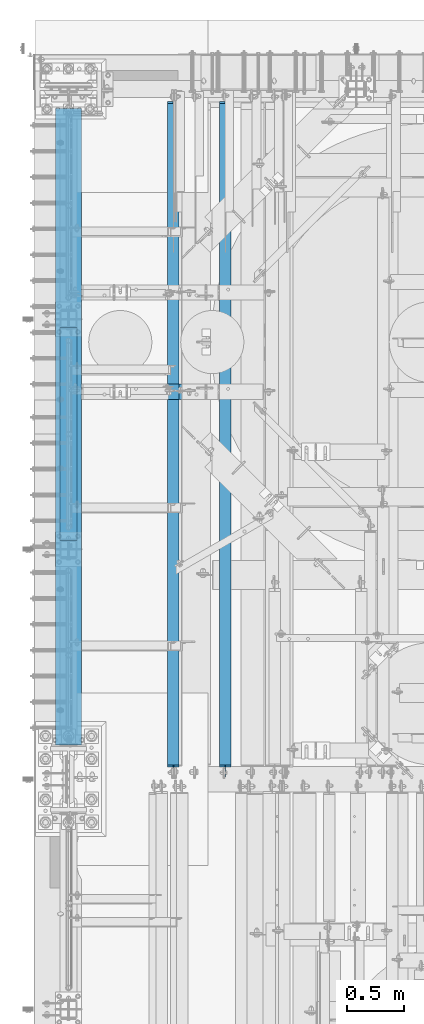
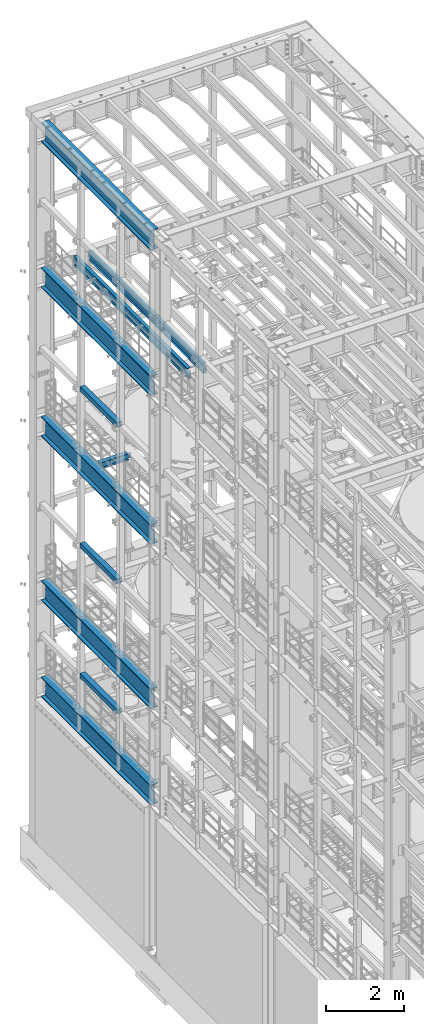
# One storey, part 1049 of 1876: 11 beams, 11 elements without a shape of their own.
"""IFC2X3 building model written with IfcOpenShell, lengths in millimetres."""

import ifcopenshell
import ifcopenshell.guid

model = None  # the IFC model being written
_history = None  # IfcOwnerHistory: only IFC2X3 demands one
_inside = {}  # id of a spatial element -> (the spatial element, [elements in it])
_under = {}  # id of a project, library or spatial element -> (it, [spatial elements below it])
_declared = {}  # id of a project -> (the project, [libraries it declares])
_typed = {}  # id of a type object -> (the type object, [elements of that type])
_made_of = {}  # id of a material, layer set ... -> (it, [elements and type objects made of it])


def new_model(schema):
    """Start an empty IFC model of exactly this schema.

    Asked for "IFC4X3", IfcOpenShell would pick the latest addendum, in which some entities
    have other attributes; the version numbers below select the first issue.
    IFC2X3 requires an IfcOwnerHistory on every rooted entity: one is made here for all.
    """
    global model, _history
    if schema == "IFC4X3":
        model = ifcopenshell.file(schema_version=(4, 3, 0, 0))
    else:
        model = ifcopenshell.file(schema=schema)
    _inside.clear()
    _under.clear()
    _declared.clear()
    _typed.clear()
    _made_of.clear()
    _history = None
    if model.schema == "IFC2X3":
        org = make("IfcOrganization", Name="unknown")
        user = make(
            "IfcPersonAndOrganization",
            ThePerson=make("IfcPerson", FamilyName="unknown"),
            TheOrganization=org,
        )
        app = make(
            "IfcApplication",
            ApplicationDeveloper=org,
            Version="unknown",
            ApplicationFullName="unknown",
            ApplicationIdentifier="unknown",
        )
        _history = make(
            "IfcOwnerHistory",
            OwningUser=user,
            OwningApplication=app,
            ChangeAction="ADDED",
            CreationDate=0,
        )
    return model


def make(cls, **values):
    """One entity of the class cls with the attributes given. An attribute that is None is left unset."""
    return model.create_entity(
        cls, **{name: value for name, value in values.items() if value is not None}
    )


def rooted(cls, **values):
    """An entity with a GlobalId (a new one), such as an element, a storey or a relation."""
    return make(cls, GlobalId=ifcopenshell.guid.new(), OwnerHistory=_history, **values)


def si_unit(unit_type, name, prefix=None):
    """IfcSIUnit, for example si_unit("LENGTHUNIT", "METRE", prefix="MILLI")."""
    return make("IfcSIUnit", UnitType=unit_type, Prefix=prefix, Name=name)


def assignment(units):
    """IfcUnitAssignment: the units of a project."""
    return None if units is None else make("IfcUnitAssignment", Units=units)


def point(xyz):
    """IfcCartesianPoint."""
    return None if xyz is None else make("IfcCartesianPoint", Coordinates=xyz)


def direction(xyz):
    """IfcDirection."""
    return None if xyz is None else make("IfcDirection", DirectionRatios=xyz)


def frame(location, z_axis=None, x_axis=None):
    """IfcAxis2Placement3D, a coordinate frame: its origin and axes. An axis left out is left unset."""
    return make(
        "IfcAxis2Placement3D",
        Location=point(location),
        Axis=direction(z_axis),
        RefDirection=direction(x_axis),
    )


def origin_with_axes():
    """The frame at (0, 0, 0) with the z axis (0, 0, 1) and the x axis (1, 0, 0) written out."""
    return frame((0.0, 0.0, 0.0), z_axis=(0.0, 0.0, 1.0), x_axis=(1.0, 0.0, 0.0))


def place(relative_to, where):
    """IfcLocalPlacement: puts the frame where relative to a parent placement (None: the world)."""
    return make(
        "IfcLocalPlacement", PlacementRelTo=relative_to, RelativePlacement=where
    )


def context(
    kind, dimensions, precision=None, world=None, true_north=None, identifier=None
):
    """IfcGeometricRepresentationContext, for example the 3D "Model" context."""
    return make(
        "IfcGeometricRepresentationContext",
        ContextIdentifier=identifier,
        ContextType=kind,
        CoordinateSpaceDimension=dimensions,
        Precision=precision,
        WorldCoordinateSystem=world,
        TrueNorth=true_north,
    )


def subcontext(parent, identifier, kind, view, scale=None):
    """IfcGeometricRepresentationSubContext, for example "Body" below "Model"."""
    return make(
        "IfcGeometricRepresentationSubContext",
        ContextIdentifier=identifier,
        ContextType=kind,
        ParentContext=parent,
        TargetScale=scale,
        TargetView=view,
    )


def project(units=None, contexts=None):
    """IfcProject with its units and contexts."""
    return rooted(
        "IfcProject",
        Name="project",
        RepresentationContexts=contexts,
        UnitsInContext=assignment(units),
    )


def spatial(cls, under=None, at=None, **own):
    """A site, building, storey or space (cls), placed at a placement, below another one or the project."""
    s = rooted(cls, ObjectPlacement=at, **own)
    if under is not None:
        _under.setdefault(under.id(), (under, []))[1].append(s)
    return s


def faces_of(points, faces, orient=None, outer=None):
    """IfcFace entities. A face is a list of loops; a loop is a list of indices into points, from 0.

    orient and outer hold one flag for each loop. By default every Orientation is true, the
    first loop of a face is its IfcFaceOuterBound and the others are IfcFaceBound.
    """
    made = []
    for i, loops in enumerate(faces):
        bounds = []
        for j, loop in enumerate(loops):
            is_outer = j == 0 if outer is None else outer[i][j]
            bounds.append(
                make(
                    "IfcFaceOuterBound" if is_outer else "IfcFaceBound",
                    Bound=make("IfcPolyLoop", Polygon=[points[k] for k in loop]),
                    Orientation=True if orient is None else orient[i][j],
                )
            )
        made.append(make("IfcFace", Bounds=bounds))
    return made


def faceted_brep(points, faces, orient=None, outer=None, voids=None):
    """IfcFacetedBrep: a solid bounded by flat faces; with voids (closed shells), ...WithVoids."""
    shared = [point(p) for p in points]
    hull = make("IfcClosedShell", CfsFaces=faces_of(shared, faces, orient, outer))
    if voids is None:
        return make("IfcFacetedBrep", Outer=hull)
    return make(
        "IfcFacetedBrepWithVoids",
        Outer=hull,
        Voids=[
            make(cls, CfsFaces=faces_of(shared, fs, o, b)) for cls, fs, o, b in voids
        ],
    )


def shape(context_of_items, identifier, shape_type, items):
    """IfcShapeRepresentation: the items that make up one representation, for example the "Body"."""
    return make(
        "IfcShapeRepresentation",
        ContextOfItems=context_of_items,
        RepresentationIdentifier=identifier,
        RepresentationType=shape_type,
        Items=items,
    )


def material(Name=None, Category=None):
    """IfcMaterial."""
    return make("IfcMaterial", Name=Name, Category=Category)


def made_of(thing, what):
    """Note that an element or type object is made of a material, layer set ...; save() writes the relation."""
    if what is not None:
        _made_of.setdefault(what.id(), (what, []))[1].append(thing)
    return thing


def type_object(cls, material=None, **own):
    """A type object (cls), such as IfcWallType, which elements share."""
    return made_of(rooted(cls, **own), material)


def element(
    cls,
    number,
    at=None,
    inside=None,
    cuts=None,
    type_object=None,
    material=None,
    context=None,
    identifier="Body",
    shape_type=None,
    held_by="IfcProductDefinitionShape",
    body=None,
    shapes=None,
    **own,
):
    """One element of the class cls, such as IfcWall. Its Tag is "e" and its number.

    at: its placement. inside: the storey or other place that contains it. cuts: it is an
    opening in that element (IfcRelVoidsElement). A single representation is given by context,
    identifier, shape_type and body (its items); several are given by shapes. held_by: the class
    of the entity that holds the representations. save() writes the other relations.
    """
    e = rooted(cls, Tag="e%d" % number, ObjectPlacement=at, **own)
    if body is not None:
        shapes = [shape(context, identifier, shape_type, body)]
    if shapes is not None:
        e.Representation = make(held_by, Representations=shapes)
    if inside is not None:
        _inside.setdefault(inside.id(), (inside, []))[1].append(e)
    if cuts is not None:
        rooted(
            "IfcRelVoidsElement", RelatingBuildingElement=cuts, RelatedOpeningElement=e
        )
    if type_object is not None:
        _typed.setdefault(type_object.id(), (type_object, []))[1].append(e)
    return made_of(e, material)


def aggregate(whole, parts):
    """IfcRelAggregates: a whole, such as a stair, and the parts it consists of."""
    return rooted("IfcRelAggregates", RelatingObject=whole, RelatedObjects=parts)


def save(model, path):
    """Write the relations noted so far, then the file.

    IfcRelAggregates (storeys below a building ...), IfcRelContainedInSpatialStructure (elements
    in a storey), IfcRelDefinesByType, IfcRelAssociatesMaterial and IfcRelDeclares: one each for
    every whole, place, type object, material and project.
    """
    for whole, parts in _under.values():
        aggregate(whole, parts)
    for where, things in _inside.values():
        rooted(
            "IfcRelContainedInSpatialStructure",
            RelatedElements=things,
            RelatingStructure=where,
        )
    for kind, things in _typed.values():
        rooted("IfcRelDefinesByType", RelatedObjects=things, RelatingType=kind)
    for what, things in _made_of.values():
        rooted("IfcRelAssociatesMaterial", RelatedObjects=things, RelatingMaterial=what)
    for by, libraries in _declared.values():
        rooted("IfcRelDeclares", RelatingContext=by, RelatedDefinitions=libraries)
    model.write(path)


model = new_model("IFC2X3")

# Units and contexts
model_context = context("Model", 3, precision=1e-05, world=origin_with_axes())
body_context = subcontext(model_context, "Body", "Model", "MODEL_VIEW")
ifc_project = project(units=[si_unit("LENGTHUNIT", "METRE", prefix="MILLI"), si_unit("AREAUNIT", "SQUARE_METRE"), si_unit("VOLUMEUNIT", "CUBIC_METRE"), si_unit("MASSUNIT", "GRAM", prefix="KILO"), si_unit("TIMEUNIT", "SECOND"), si_unit("PLANEANGLEUNIT", "RADIAN"), si_unit("SOLIDANGLEUNIT", "STERADIAN"), si_unit("THERMODYNAMICTEMPERATUREUNIT", "DEGREE_CELSIUS"), si_unit("LUMINOUSINTENSITYUNIT", "LUMEN")], contexts=[model_context])

# Site, building, storey
site_placement = place(None, origin_with_axes())
site = spatial("IfcSite", under=ifc_project, at=site_placement, CompositionType="ELEMENT")
building_placement = place(site_placement, origin_with_axes())
building = spatial("IfcBuilding", under=site, at=building_placement, Name="Undefined", CompositionType="ELEMENT")
storey_placement = place(building_placement, origin_with_axes())
storey = spatial("IfcBuildingStorey", under=building, at=storey_placement, Name="Undefined", CompositionType="ELEMENT", Elevation=0.0)

# Assembly, beam
assembly_1_placement = place(storey_placement, origin_with_axes())
assembly_1 = element("IfcElementAssembly", 1, at=assembly_1_placement, inside=storey, Name="BEAM", AssemblyPlace="NOTDEFINED", PredefinedType="RIGID_FRAME")
ifc_material_1 = material()
beam_type_1 = type_object("IfcBeamType", Name="HSS6X6X3/8", PredefinedType="NOTDEFINED")
beam_1_placement = place(assembly_1_placement, frame((0.0, 9652.0, 15335.25), z_axis=(-1.0, 0.0, 0.0), x_axis=(0.0, 1.0, 0.0)))
beam_1 = element("IfcBeam", 2, at=beam_1_placement, type_object=beam_type_1, material=ifc_material_1, Name="BEAM", ObjectType="HSS6X6X3/8", context=body_context, shape_type="Brep", body=[
    faceted_brep([(76.2000000000007, 66.6749999999993, -66.6750000000002), (76.2000000000007, -66.6749999999993, -66.6750000000002), (1955.8, -66.6749999999993, -66.675), (1955.8, 66.6749999999993, -66.675), (76.2000000000007, -66.6749999999993, 66.6750000000002), (1955.8, -66.6749999999993, 66.675), (76.2000000000007, 66.6749999999993, 66.6750000000002), (1955.8, 66.6749999999993, 66.675), (76.2000000000007, 76.2000000000007, -76.1999999999998), (76.2000000000007, 76.2000000000007, 76.1999999999998), (1955.8, 76.2000000000007, 76.2), (1955.8, 76.2000000000007, -76.2), (76.2000000000007, -76.2000000000007, 76.1999999999998), (1955.8, -76.2000000000007, 76.2), (76.2000000000007, -76.2000000000007, -76.1999999999998), (1955.8, -76.2000000000007, -76.2)], [[[0, 1, 2, 3]], [[1, 4, 5, 2]], [[4, 6, 7, 5]], [[6, 0, 3, 7]], [[8, 9, 10, 11]], [[9, 12, 13, 10]], [[12, 14, 15, 13]], [[14, 8, 11, 15]], [[13, 15, 11, 10], [5, 7, 3, 2]], [[14, 12, 9, 8], [6, 4, 1, 0]]]),
])
aggregate(assembly_1, [beam_1])

assembly_2_placement = place(storey_placement, origin_with_axes())
assembly_2 = element("IfcElementAssembly", 3, at=assembly_2_placement, inside=storey, Name="BEAM", AssemblyPlace="NOTDEFINED", PredefinedType="RIGID_FRAME")
beam_2_placement = place(assembly_2_placement, frame((0.0, 9652.0, 10420.35), z_axis=(-1.0, 0.0, 0.0), x_axis=(0.0, 1.0, 0.0)))
beam_2 = element("IfcBeam", 4, at=beam_2_placement, type_object=beam_type_1, material=ifc_material_1, Name="BEAM", ObjectType="HSS6X6X3/8", context=body_context, shape_type="Brep", body=[
    faceted_brep([(76.2000000000007, 66.6749999999993, -66.6750000000002), (76.2000000000007, -66.6749999999993, -66.6750000000002), (1955.8, -66.6749999999993, -66.675), (1955.8, 66.6749999999993, -66.675), (76.2000000000007, -66.6749999999993, 66.6750000000002), (1955.8, -66.6749999999993, 66.675), (76.2000000000007, 66.6749999999993, 66.6750000000002), (1955.8, 66.6749999999993, 66.675), (76.2000000000007, 76.2000000000007, -76.1999999999998), (76.2000000000007, 76.2000000000007, 76.1999999999998), (1955.8, 76.2000000000007, 76.2), (1955.8, 76.2000000000007, -76.2), (76.2000000000007, -76.2000000000007, 76.1999999999998), (1955.8, -76.2000000000007, 76.2), (76.2000000000007, -76.2000000000007, -76.1999999999998), (1955.8, -76.2000000000007, -76.2)], [[[0, 1, 2, 3]], [[1, 4, 5, 2]], [[4, 6, 7, 5]], [[6, 0, 3, 7]], [[8, 9, 10, 11]], [[9, 12, 13, 10]], [[12, 14, 15, 13]], [[14, 8, 11, 15]], [[13, 15, 11, 10], [5, 7, 3, 2]], [[14, 12, 9, 8], [6, 4, 1, 0]]]),
])
aggregate(assembly_2, [beam_2])

assembly_3_placement = place(storey_placement, origin_with_axes())
assembly_3 = element("IfcElementAssembly", 5, at=assembly_3_placement, inside=storey, Name="BEAM", AssemblyPlace="NOTDEFINED", PredefinedType="RIGID_FRAME")
beam_3_placement = place(assembly_3_placement, frame((0.0, 9652.0, 6330.95), z_axis=(-1.0, 0.0, 0.0), x_axis=(0.0, 1.0, 0.0)))
beam_3 = element("IfcBeam", 6, at=beam_3_placement, type_object=beam_type_1, material=ifc_material_1, Name="BEAM", ObjectType="HSS6X6X3/8", context=body_context, shape_type="Brep", body=[
    faceted_brep([(76.2000000000007, 66.6749999999993, -66.6750000000002), (76.2000000000007, -66.6749999999993, -66.6750000000002), (1955.8, -66.6749999999993, -66.675), (1955.8, 66.6749999999993, -66.675), (76.2000000000007, -66.6749999999993, 66.6750000000002), (1955.8, -66.6749999999993, 66.675), (76.2000000000007, 66.6749999999993, 66.6750000000002), (1955.8, 66.6749999999993, 66.675), (76.2000000000007, 76.2000000000007, -76.1999999999998), (76.2000000000007, 76.2000000000007, 76.1999999999998), (1955.8, 76.2000000000007, 76.2), (1955.8, 76.2000000000007, -76.2), (76.2000000000007, -76.2000000000007, 76.1999999999998), (1955.8, -76.2000000000007, 76.2), (76.2000000000007, -76.2000000000007, -76.1999999999998), (1955.8, -76.2000000000007, -76.2)], [[[0, 1, 2, 3]], [[1, 4, 5, 2]], [[4, 6, 7, 5]], [[6, 0, 3, 7]], [[8, 9, 10, 11]], [[9, 12, 13, 10]], [[12, 14, 15, 13]], [[14, 8, 11, 15]], [[13, 15, 11, 10], [5, 7, 3, 2]], [[14, 12, 9, 8], [6, 4, 1, 0]]]),
])
aggregate(assembly_3, [beam_3])

assembly_4_placement = place(storey_placement, origin_with_axes())
assembly_4 = element("IfcElementAssembly", 7, at=assembly_4_placement, inside=storey, Name="BEAM", AssemblyPlace="NOTDEFINED", PredefinedType="RIGID_FRAME")
ifc_material_2 = material(Name="STEEL/A992")
beam_type_2 = type_object("IfcBeamType", Name="W12X16", PredefinedType="NOTDEFINED")
beam_4_placement = place(assembly_4_placement, frame((1384.3, 7620.0, 17830.8), z_axis=(0.0, 0.0, 1.0), x_axis=(0.0, 1.0, 0.0)))
beam_4 = element("IfcBeam", 8, at=beam_4_placement, type_object=beam_type_2, material=ifc_material_2, Name="BEAM", ObjectType="W12X16", context=body_context, shape_type="Brep", body=[
    faceted_brep([(19.84375, -3.17499999999995, -126.999999999996), (19.84375, 3.17499999999995, -126.999999999996), (96.0437501907345, 3.17500002364682, -126.999999999996), (96.0437501907345, -3.17499999999995, -126.999999999996), (100.90382970878, 3.17500002380461, -127.966729922584), (100.90382970878, -3.17499999999995, -127.966729922584), (105.024006176934, 3.17500002425209, -130.719743823061), (105.024006176934, -3.17499999999995, -130.719743823061), (107.777020077412, 3.17500002492102, -134.839920291215), (107.777020077412, -3.17499999999995, -134.839920291215), (108.74375, -3.17499999999995, -139.699999809261), (108.74375, 3.17500002570978, -139.699999809261), (108.74375, 3.17500009516311, -146.049999999999), (108.74375, 50.8, -146.049999999999), (108.74375, 50.8, -152.400000000001), (108.74375, -50.8, -152.400000000001), (108.74375, -50.8, -146.049999999999), (108.74375, -3.17499999999995, -146.049999999999), (5969.79375, 50.8, 146.049999999999), (5969.79375, 3.17499999999995, 146.049999999999), (126.20625, 3.17499999999995, 146.049999999999), (126.20625, 50.8, 146.049999999999), (113.506250190735, -3.17499999999995, 107.950000000004), (113.506250190735, 3.17499998606149, 107.950000000004), (19.84375, 3.17499999999995, 107.950000000004), (19.84375, -3.17499999999995, 107.950000000004), (118.366329708781, -3.17499999999995, 108.916729922592), (118.366329708781, 3.17499998590552, 108.916729922592), (122.486506176934, -3.17499999999995, 111.669743823069), (122.486506176934, 3.17499998546009, 111.669743823069), (125.239520077413, -3.17499999999995, 115.789920291223), (125.239520077413, 3.17499998479298, 115.789920291223), (126.20625, -3.17499999999995, 120.64999980927), (126.20625, 3.17499998400558, 120.64999980927), (5969.79375, -50.8, 152.400000000001), (5969.79375, 50.8, 152.400000000001), (126.20625, 50.8, 152.400000000001), (126.20625, -50.8, 152.400000000001), (5969.79375, -50.8, 146.049999999999), (126.20625, -50.8, 146.049999999999), (5969.79375, -3.17499999999995, 146.049999999999), (126.20625, -3.17499999999995, 146.049999999999), (5969.79375, -3.17499999999995, 120.64999980927), (5969.79375, 3.17499999999995, 120.64999980927), (5970.76047992259, -3.17499999999995, 115.789920291223), (5970.76047992259, 3.17499999999995, 115.789920291223), (5973.51349382307, -3.17499999999995, 111.669743823069), (5973.51349382307, 3.17499999999995, 111.669743823069), (5977.63367029122, -3.17499999999995, 108.916729922592), (5977.63367029122, 3.17499999999995, 108.916729922592), (5982.49374980927, -3.17499999999995, 107.950000000004), (5982.49374980927, 3.17499999999995, 107.950000000004), (6076.15625, -3.17499999999995, 107.950000000004), (6076.15625, 3.17499999999995, 107.950000000004), (6076.15625, -3.17499999999995, -126.999999999996), (6076.15625, 3.17499999999995, -126.999999999996), (5999.95624980926, -3.17499999999995, -126.999999999996), (5999.95624980926, 3.17499999999995, -126.999999999996), (5995.09617029122, -3.17499999999995, -127.966729922584), (5995.09617029122, 3.17499999999995, -127.966729922584), (5990.97599382306, -3.17499999999995, -130.719743823061), (5990.97599382306, 3.17499999999995, -130.719743823061), (5988.22297992259, -3.17499999999995, -134.839920291215), (5988.22297992259, 3.17499999999995, -134.839920291215), (5987.25625, -3.17499999999995, -139.699999809261), (5987.25625, 3.17499999999995, -139.699999809261), (5987.25625, -3.17499999999995, -146.049999999999), (5987.25625, -50.8, -146.049999999999), (5987.25625, -50.8, -152.400000000001), (5987.25625, 50.8, -152.400000000001), (5987.25625, 50.8, -146.049999999999), (5987.25625, 3.17499999999995, -146.049999999999)], [[[0, 1, 2, 3]], [[3, 2, 4, 5]], [[5, 4, 6, 7]], [[7, 6, 8, 9]], [[10, 11, 12, 13, 14, 15, 16, 17]], [[9, 8, 11, 10]], [[18, 19, 20, 21]], [[22, 23, 24, 25]], [[26, 27, 23, 22]], [[28, 29, 27, 26]], [[30, 31, 29, 28]], [[32, 33, 31, 30]], [[34, 35, 36, 37]], [[38, 34, 37, 39]], [[40, 38, 39, 41]], [[37, 36, 21, 20, 33, 32, 41, 39]], [[35, 18, 21, 36]], [[34, 38, 40, 42, 43, 19, 18, 35]], [[44, 45, 43, 42]], [[46, 47, 45, 44]], [[48, 49, 47, 46]], [[50, 51, 49, 48]], [[52, 53, 51, 50]], [[53, 52, 54, 55]], [[54, 56, 57, 55]], [[58, 59, 57, 56]], [[60, 61, 59, 58]], [[62, 63, 61, 60]], [[64, 65, 63, 62]], [[66, 67, 68, 69, 70, 71, 65, 64]], [[67, 66, 17, 16]], [[68, 67, 16, 15]], [[69, 68, 15, 14]], [[70, 69, 14, 13]], [[71, 70, 13, 12]], [[6, 4, 2, 1, 24, 23, 27, 29, 31, 33, 20, 19, 43, 45, 47, 49, 51, 53, 55, 57, 59, 61, 63, 65, 71, 12, 11, 8]], [[25, 24, 1, 0]], [[66, 64, 62, 60, 58, 56, 54, 52, 50, 48, 46, 44, 42, 40, 41, 32, 30, 28, 26, 22, 25, 0, 3, 5, 7, 9, 10, 17]]]),
])
aggregate(assembly_4, [beam_4])

assembly_5_placement = place(storey_placement, origin_with_axes())
assembly_5 = element("IfcElementAssembly", 9, at=assembly_5_placement, inside=storey, Name="BEAM", AssemblyPlace="NOTDEFINED", PredefinedType="RIGID_FRAME")
beam_5_placement = place(assembly_5_placement, frame((927.1, 7620.00000000001, 17830.8), z_axis=(0.0, 0.0, 1.0), x_axis=(0.0, 1.0, 0.0)))
beam_5 = element("IfcBeam", 10, at=beam_5_placement, type_object=beam_type_2, material=ifc_material_2, Name="BEAM", ObjectType="W12X16", context=body_context, shape_type="Brep", body=[
    faceted_brep([(19.84375, -3.17499999999995, -126.999999999996), (19.84375, 3.17499999999995, -126.999999999996), (96.0437501907345, 3.17500002364682, -126.999999999996), (96.0437501907345, -3.17499999999995, -126.999999999996), (100.90382970878, 3.17500002380461, -127.966729922584), (100.90382970878, -3.17499999999995, -127.966729922584), (105.024006176934, 3.17500002425209, -130.719743823061), (105.024006176934, -3.17499999999995, -130.719743823061), (107.777020077412, 3.17500002492102, -134.839920291215), (107.777020077412, -3.17499999999995, -134.839920291215), (108.74375, -3.17499999999995, -139.699999809261), (108.74375, 3.17500002570978, -139.699999809261), (108.74375, 3.17500009516311, -146.049999999999), (108.74375, 50.8, -146.049999999999), (108.74375, 50.8, -152.400000000001), (108.74375, -50.8, -152.400000000001), (108.74375, -50.8, -146.049999999999), (108.74375, -3.17499999999995, -146.049999999999), (5969.79375, 50.8, 146.049999999999), (5969.79375, 3.17499999999995, 146.049999999999), (126.20625, 3.17499999999995, 146.049999999999), (126.20625, 50.8, 146.049999999999), (113.506250190735, -3.17499999999995, 107.950000000004), (113.506250190735, 3.17499998606149, 107.950000000004), (19.84375, 3.17499999999995, 107.950000000004), (19.84375, -3.17499999999995, 107.950000000004), (118.366329708781, -3.17499999999995, 108.916729922592), (118.366329708781, 3.17499998590552, 108.916729922592), (122.486506176934, -3.17499999999995, 111.669743823069), (122.486506176934, 3.17499998546009, 111.669743823069), (125.239520077413, -3.17499999999995, 115.789920291223), (125.239520077413, 3.17499998479298, 115.789920291223), (126.20625, -3.17499999999995, 120.64999980927), (126.20625, 3.17499998400558, 120.64999980927), (5969.79375, -50.8, 152.400000000001), (5969.79375, 50.8, 152.400000000001), (126.20625, 50.8, 152.400000000001), (126.20625, -50.8, 152.400000000001), (5969.79375, -50.8, 146.049999999999), (126.20625, -50.8, 146.049999999999), (5969.79375, -3.17499999999995, 146.049999999999), (126.20625, -3.17499999999995, 146.049999999999), (5969.79375, -3.17499999999995, 120.64999980927), (5969.79375, 3.17499999999995, 120.64999980927), (5970.76047992259, -3.17499999999995, 115.789920291223), (5970.76047992259, 3.17499999999995, 115.789920291223), (5973.51349382307, -3.17499999999995, 111.669743823069), (5973.51349382307, 3.17499999999995, 111.669743823069), (5977.63367029122, -3.17499999999995, 108.916729922592), (5977.63367029122, 3.17499999999995, 108.916729922592), (5982.49374980927, -3.17499999999995, 107.950000000004), (5982.49374980927, 3.17499999999995, 107.950000000004), (6076.15625, -3.17499999999995, 107.950000000004), (6076.15625, 3.17499999999995, 107.950000000004), (6076.15625, -3.17499999999995, -126.999999999996), (6076.15625, 3.17499999999995, -126.999999999996), (5999.95624980926, -3.17499999999995, -126.999999999996), (5999.95624980926, 3.17499999999995, -126.999999999996), (5995.09617029122, -3.17499999999995, -127.966729922584), (5995.09617029122, 3.17499999999995, -127.966729922584), (5990.97599382306, -3.17499999999995, -130.719743823061), (5990.97599382306, 3.17499999999995, -130.719743823061), (5988.22297992259, -3.17499999999995, -134.839920291215), (5988.22297992259, 3.17499999999995, -134.839920291215), (5987.25625, -3.17499999999995, -139.699999809261), (5987.25625, 3.17499999999995, -139.699999809261), (5987.25625, -3.17499999999995, -146.049999999999), (5987.25625, -50.8, -146.049999999999), (5987.25625, -50.8, -152.400000000001), (5987.25625, 50.8, -152.400000000001), (5987.25625, 50.8, -146.049999999999), (5987.25625, 3.17499999999995, -146.049999999999)], [[[0, 1, 2, 3]], [[3, 2, 4, 5]], [[5, 4, 6, 7]], [[7, 6, 8, 9]], [[10, 11, 12, 13, 14, 15, 16, 17]], [[9, 8, 11, 10]], [[18, 19, 20, 21]], [[22, 23, 24, 25]], [[26, 27, 23, 22]], [[28, 29, 27, 26]], [[30, 31, 29, 28]], [[32, 33, 31, 30]], [[34, 35, 36, 37]], [[38, 34, 37, 39]], [[40, 38, 39, 41]], [[37, 36, 21, 20, 33, 32, 41, 39]], [[35, 18, 21, 36]], [[34, 38, 40, 42, 43, 19, 18, 35]], [[44, 45, 43, 42]], [[46, 47, 45, 44]], [[48, 49, 47, 46]], [[50, 51, 49, 48]], [[52, 53, 51, 50]], [[53, 52, 54, 55]], [[54, 56, 57, 55]], [[58, 59, 57, 56]], [[60, 61, 59, 58]], [[62, 63, 61, 60]], [[64, 65, 63, 62]], [[66, 67, 68, 69, 70, 71, 65, 64]], [[67, 66, 17, 16]], [[68, 67, 16, 15]], [[69, 68, 15, 14]], [[70, 69, 14, 13]], [[71, 70, 13, 12]], [[6, 4, 2, 1, 24, 23, 27, 29, 31, 33, 20, 19, 43, 45, 47, 49, 51, 53, 55, 57, 59, 61, 63, 65, 71, 12, 11, 8]], [[25, 24, 1, 0]], [[66, 64, 62, 60, 58, 56, 54, 52, 50, 48, 46, 44, 42, 40, 41, 32, 30, 28, 26, 22, 25, 0, 3, 5, 7, 9, 10, 17]]]),
])
aggregate(assembly_5, [beam_5])

assembly_6_placement = place(storey_placement, origin_with_axes())
assembly_6 = element("IfcElementAssembly", 11, at=assembly_6_placement, inside=storey, Name="BEAM", AssemblyPlace="NOTDEFINED", PredefinedType="RIGID_FRAME")
beam_type_3 = type_object("IfcBeamType", Name="W8X18", PredefinedType="NOTDEFINED")
beam_6_placement = place(assembly_6_placement, frame((-1.70530256582424e-13, 11042.65, 13206.4125), z_axis=(0.0, 0.0, 1.0), x_axis=(1.0, 0.0, 0.0)))
beam_6 = element("IfcBeam", 12, at=beam_6_placement, type_object=beam_type_3, material=ifc_material_2, Name="BEAM", ObjectType="W8X18", context=body_context, shape_type="Brep", body=[
    faceted_brep([(19.8437500000002, -3.17500000000018, -77.7874999999985), (19.8437500000002, 3.17500000000018, -77.7874999999985), (96.043750190735, 3.17499999999927, -77.7875000000004), (96.043750190735, -3.17499999999927, -77.7875000000004), (100.903829708781, 3.17499999999927, -78.7542299225879), (100.903829708781, -3.17499999999927, -78.7542299225879), (105.024006176934, 3.17499999999927, -81.5072438230654), (105.024006176934, -3.17499999999927, -81.5072438230654), (107.777020077412, 3.17499999999927, -85.6274202912191), (107.777020077412, -3.17499999999927, -85.6274202912191), (108.74375, -3.17499999999927, -90.4874998092655), (108.74375, 3.17499999999927, -90.4874998092655), (108.74375, 3.17499999999927, -95.25), (108.74375, 66.6749999999993, -95.25), (108.74375, 66.6750000000002, -103.1875), (108.74375, -66.6750000000002, -103.1875), (108.74375, -66.6749999999993, -95.25), (108.74375, -3.17499999999927, -95.25), (127.79375, 3.17499999999927, 95.25), (127.79375, 66.6749999999993, 95.25), (977.900004800633, 66.6749999999993, 95.25), (977.900004800633, 3.17499999999927, 95.25), (115.093750190735, -3.17499999999927, 71.4375), (115.093750190735, 3.17499999999927, 71.4375), (19.8437499999999, 3.17499999999927, 71.4375), (19.8437499999999, -3.17499999999927, 71.4375), (119.953829708781, -3.17499999999927, 72.4042299225875), (119.953829708781, 3.17499999999927, 72.4042299225875), (124.074006176934, -3.17499999999927, 75.1572438230651), (124.074006176934, 3.17499999999927, 75.1572438230651), (126.827020077412, -3.17499999999927, 79.2774202912187), (126.827020077412, 3.17499999999927, 79.2774202912187), (127.79375, -3.17499999999927, 84.1374998092651), (127.79375, 3.17499999999927, 84.1374998092651), (127.79375, -66.6749999999993, 103.1875), (127.79375, 66.6749999999993, 103.1875), (127.79375, -3.17499999999927, 95.25), (127.79375, -66.6749999999993, 95.25), (977.900004800633, -3.17499999999927, 95.25), (977.900004800633, -66.6749999999993, 95.25), (977.900004800633, -66.6749999999993, 103.1875), (977.900004800633, 66.6749999999993, 103.1875), (977.900004800633, -3.17499999999927, 84.1374998092651), (977.900004800633, 3.17499999999927, 84.1374998092651), (978.866734723221, -3.17499999999927, 79.2774202912187), (978.866734723221, 3.17499999999927, 79.2774202912187), (981.619748623699, -3.17499999999927, 75.1572438230651), (981.619748623699, 3.17499999999927, 75.1572438230651), (985.739925091853, -3.17499999999927, 72.4042299225875), (985.739925091853, 3.17499999999927, 72.4042299225875), (990.600004609898, -3.17499999999927, 71.4375), (990.600004609898, 3.17499999999927, 71.4375), (1104.90000480063, -3.17499999999927, 71.4375), (1104.90000480063, 3.17499999999927, 71.4375), (1104.90000480063, -3.17499999999927, -77.7875000000004), (1104.90000480063, 3.17499999999927, -77.7875000000004), (1028.7000046099, -3.17499999999927, -77.7875000000004), (1028.7000046099, 3.17499999999927, -77.7875000000004), (1023.83992509185, -3.17499999999927, -78.7542299225879), (1023.83992509185, 3.17499999999927, -78.7542299225879), (1019.7197486237, -3.17499999999927, -81.5072438230654), (1019.7197486237, 3.17499999999927, -81.5072438230654), (1016.96673472322, -3.17499999999927, -85.6274202912191), (1016.96673472322, 3.17499999999927, -85.6274202912191), (1016.00000480063, -3.17499999999927, -90.4874998092655), (1016.00000480063, 3.17499999999927, -90.4874998092655), (1016.00000480063, -3.17499999999927, -95.25), (1016.00000480063, -66.6749999999993, -95.25), (1016.00000480063, -66.6749999999993, -103.1875), (1016.00000480063, 66.6749999999993, -103.1875), (1016.00000480063, 66.6749999999993, -95.25), (1016.00000480063, 3.17499999999927, -95.25)], [[[0, 1, 2, 3]], [[3, 2, 4, 5]], [[5, 4, 6, 7]], [[7, 6, 8, 9]], [[10, 11, 12, 13, 14, 15, 16, 17]], [[9, 8, 11, 10]], [[18, 19, 20, 21]], [[22, 23, 24, 25]], [[26, 27, 23, 22]], [[28, 29, 27, 26]], [[30, 31, 29, 28]], [[32, 33, 31, 30]], [[34, 35, 19, 18, 33, 32, 36, 37]], [[37, 36, 38, 39]], [[34, 37, 39, 40]], [[35, 34, 40, 41]], [[19, 35, 41, 20]], [[40, 39, 38, 42, 43, 21, 20, 41]], [[44, 45, 43, 42]], [[46, 47, 45, 44]], [[48, 49, 47, 46]], [[50, 51, 49, 48]], [[52, 53, 51, 50]], [[53, 52, 54, 55]], [[54, 56, 57, 55]], [[58, 59, 57, 56]], [[60, 61, 59, 58]], [[62, 63, 61, 60]], [[64, 65, 63, 62]], [[66, 67, 68, 69, 70, 71, 65, 64]], [[67, 66, 17, 16]], [[68, 67, 16, 15]], [[69, 68, 15, 14]], [[70, 69, 14, 13]], [[71, 70, 13, 12]], [[6, 4, 2, 1, 24, 23, 27, 29, 31, 33, 18, 21, 43, 45, 47, 49, 51, 53, 55, 57, 59, 61, 63, 65, 71, 12, 11, 8]], [[25, 24, 1, 0]], [[66, 64, 62, 60, 58, 56, 54, 52, 50, 48, 46, 44, 42, 38, 36, 32, 30, 28, 26, 22, 25, 0, 3, 5, 7, 9, 10, 17]]]),
])
aggregate(assembly_6, [beam_6])

assembly_7_placement = place(storey_placement, origin_with_axes())
assembly_7 = element("IfcElementAssembly", 13, at=assembly_7_placement, inside=storey, Name="BEAM", AssemblyPlace="NOTDEFINED", PredefinedType="RIGID_FRAME")
beam_type_4 = type_object("IfcBeamType", Name="W24X103", PredefinedType="NOTDEFINED")
beam_7_placement = place(assembly_7_placement, frame((0.0, 7620.0, 17672.05), z_axis=(0.0, 0.0, 1.0), x_axis=(0.0, 1.0, 0.0)))
beam_7 = element("IfcBeam", 14, at=beam_7_placement, type_object=beam_type_4, material=ifc_material_2, Name="BEAM", ObjectType="W24X103", context=body_context, shape_type="Brep", body=[
    faceted_brep([(301.625, -114.3, -285.75), (301.625, -114.3, -311.150000000001), (5922.9625, -114.3, -311.150000000001), (5922.9625, -114.3, -285.75), (301.625, -7.14375000000018, -285.75), (5922.9625, -7.14375000000018, -285.75), (301.625, -7.14375000000018, 285.75), (5922.9625, -7.14375000000018, 285.75), (301.625, -114.3, 285.75), (5922.9625, -114.3, 285.75), (301.625, -114.3, 311.150000000001), (5922.9625, -114.3, 311.150000000001), (301.625, 114.3, 311.150000000001), (5922.9625, 114.3, 311.150000000001), (301.625, 114.3, 285.75), (5922.9625, 114.3, 285.75), (301.625, 7.14375000000018, 285.75), (5922.9625, 7.14375000000018, 285.75), (301.625, 7.14375000000018, -285.75), (5922.9625, 7.14375000000018, -285.75), (301.625, 114.3, -285.75), (5922.9625, 114.3, -285.75), (301.625, 114.3, -311.150000000001), (5922.9625, 114.3, -311.150000000001)], [[[0, 1, 2, 3]], [[4, 0, 3, 5]], [[6, 4, 5, 7]], [[8, 6, 7, 9]], [[10, 8, 9, 11]], [[12, 10, 11, 13]], [[14, 12, 13, 15]], [[16, 14, 15, 17]], [[18, 16, 17, 19]], [[20, 18, 19, 21]], [[1, 0, 4, 6, 8, 10, 12, 14, 16, 18, 20, 22]], [[1, 22, 23, 2]], [[19, 17, 15, 13, 11, 9, 7, 5, 3, 2, 23, 21]], [[22, 20, 21, 23]]]),
])
aggregate(assembly_7, [beam_7])

assembly_8_placement = place(storey_placement, origin_with_axes())
assembly_8 = element("IfcElementAssembly", 15, at=assembly_8_placement, inside=storey, Name="BEAM", AssemblyPlace="NOTDEFINED", PredefinedType="RIGID_FRAME")
beam_8_placement = place(assembly_8_placement, frame((0.0, 7620.0, 12998.45), z_axis=(0.0, 0.0, 1.0), x_axis=(0.0, 1.0, 0.0)))
beam_8 = element("IfcBeam", 16, at=beam_8_placement, type_object=beam_type_4, material=ifc_material_2, Name="BEAM", ObjectType="W24X103", context=body_context, shape_type="Brep", body=[
    faceted_brep([(301.625, -114.3, -285.75), (301.625, -114.3, -311.150000000001), (5922.9625, -114.3, -311.150000000001), (5922.9625, -114.3, -285.75), (301.625, -7.14375000000018, -285.75), (5922.9625, -7.14375000000018, -285.75), (301.625, -7.14375000000018, 285.75), (5922.9625, -7.14375000000018, 285.75), (301.625, -114.3, 285.75), (5922.9625, -114.3, 285.75), (301.625, -114.3, 311.150000000001), (5922.9625, -114.3, 311.150000000001), (301.625, 114.3, 311.150000000001), (5922.9625, 114.3, 311.150000000001), (301.625, 114.3, 285.75), (5922.9625, 114.3, 285.75), (301.625, 7.14375000000018, 285.75), (5922.9625, 7.14375000000018, 285.75), (301.625, 7.14375000000018, -285.75), (5922.9625, 7.14375000000018, -285.75), (301.625, 114.3, -285.75), (5922.9625, 114.3, -285.75), (301.625, 114.3, -311.150000000001), (5922.9625, 114.3, -311.150000000001)], [[[0, 1, 2, 3]], [[4, 0, 3, 5]], [[6, 4, 5, 7]], [[8, 6, 7, 9]], [[10, 8, 9, 11]], [[12, 10, 11, 13]], [[14, 12, 13, 15]], [[16, 14, 15, 17]], [[18, 16, 17, 19]], [[20, 18, 19, 21]], [[1, 0, 4, 6, 8, 10, 12, 14, 16, 18, 20, 22]], [[1, 22, 23, 2]], [[19, 17, 15, 13, 11, 9, 7, 5, 3, 2, 23, 21]], [[22, 20, 21, 23]]]),
])
aggregate(assembly_8, [beam_8])

assembly_9_placement = place(storey_placement, origin_with_axes())
assembly_9 = element("IfcElementAssembly", 17, at=assembly_9_placement, inside=storey, Name="BEAM", AssemblyPlace="NOTDEFINED", PredefinedType="RIGID_FRAME")
beam_9_placement = place(assembly_9_placement, frame((0.0, 7620.0, 7842.25), z_axis=(0.0, 0.0, 1.0), x_axis=(0.0, 1.0, 0.0)))
beam_9 = element("IfcBeam", 18, at=beam_9_placement, type_object=beam_type_4, material=ifc_material_2, Name="BEAM", ObjectType="W24X103", context=body_context, shape_type="Brep", body=[
    faceted_brep([(301.625, -114.3, -285.75), (301.625, -114.3, -311.150000000001), (5922.9625, -114.3, -311.150000000001), (5922.9625, -114.3, -285.75), (301.625, -7.14375000000018, -285.75), (5922.9625, -7.14375000000018, -285.75), (301.625, -7.14375000000018, 285.75), (5922.9625, -7.14375000000018, 285.75), (301.625, -114.3, 285.75), (5922.9625, -114.3, 285.75), (301.625, -114.3, 311.150000000001), (5922.9625, -114.3, 311.150000000001), (301.625, 114.3, 311.150000000001), (5922.9625, 114.3, 311.150000000001), (301.625, 114.3, 285.75), (5922.9625, 114.3, 285.75), (301.625, 7.14375000000018, 285.75), (5922.9625, 7.14375000000018, 285.75), (301.625, 7.14375000000018, -285.75), (5922.9625, 7.14375000000018, -285.75), (301.625, 114.3, -285.75), (5922.9625, 114.3, -285.75), (301.625, 114.3, -311.150000000001), (5922.9625, 114.3, -311.150000000001)], [[[0, 1, 2, 3]], [[4, 0, 3, 5]], [[6, 4, 5, 7]], [[8, 6, 7, 9]], [[10, 8, 9, 11]], [[12, 10, 11, 13]], [[14, 12, 13, 15]], [[16, 14, 15, 17]], [[18, 16, 17, 19]], [[20, 18, 19, 21]], [[1, 0, 4, 6, 8, 10, 12, 14, 16, 18, 20, 22]], [[1, 22, 23, 2]], [[19, 17, 15, 13, 11, 9, 7, 5, 3, 2, 23, 21]], [[22, 20, 21, 23]]]),
])
aggregate(assembly_9, [beam_9])

assembly_10_placement = place(storey_placement, origin_with_axes())
assembly_10 = element("IfcElementAssembly", 19, at=assembly_10_placement, inside=storey, Name="BEAM", AssemblyPlace="NOTDEFINED", PredefinedType="RIGID_FRAME")
beam_10_placement = place(assembly_10_placement, frame((0.0, 7620.0, 22244.05), z_axis=(0.0, 0.0, 1.0), x_axis=(0.0, 1.0, 0.0)))
beam_10 = element("IfcBeam", 20, at=beam_10_placement, type_object=beam_type_4, material=ifc_material_2, Name="BEAM", ObjectType="W24X103", context=body_context, shape_type="Brep", body=[
    faceted_brep([(301.625, -114.3, -285.75), (301.625, -114.3, -311.150000000001), (5922.9625, -114.3, -311.150000000001), (5922.9625, -114.3, -285.75), (301.625, -7.14375000000018, -285.75), (5922.9625, -7.14375000000018, -285.75), (301.625, -7.14375000000018, 285.75), (5922.9625, -7.14375000000018, 285.75), (301.625, -114.3, 285.75), (5922.9625, -114.3, 285.75), (301.625, -114.3, 311.150000000001), (5922.9625, -114.3, 311.150000000001), (301.625, 114.3, 311.150000000001), (5922.9625, 114.3, 311.150000000001), (301.625, 114.3, 285.75), (5922.9625, 114.3, 285.75), (301.625, 7.14375000000018, 285.75), (5922.9625, 7.14375000000018, 285.75), (301.625, 7.14375000000018, -285.75), (5922.9625, 7.14375000000018, -285.75), (301.625, 114.3, -285.75), (5922.9625, 114.3, -285.75), (301.625, 114.3, -311.150000000001), (5922.9625, 114.3, -311.150000000001)], [[[0, 1, 2, 3]], [[4, 0, 3, 5]], [[6, 4, 5, 7]], [[8, 6, 7, 9]], [[10, 8, 9, 11]], [[12, 10, 11, 13]], [[14, 12, 13, 15]], [[16, 14, 15, 17]], [[18, 16, 17, 19]], [[20, 18, 19, 21]], [[1, 0, 4, 6, 8, 10, 12, 14, 16, 18, 20, 22]], [[1, 22, 23, 2]], [[19, 17, 15, 13, 11, 9, 7, 5, 3, 2, 23, 21]], [[22, 20, 21, 23]]]),
])
aggregate(assembly_10, [beam_10])

assembly_11_placement = place(storey_placement, origin_with_axes())
assembly_11 = element("IfcElementAssembly", 21, at=assembly_11_placement, inside=storey, Name="BEAM", AssemblyPlace="NOTDEFINED", PredefinedType="RIGID_FRAME")
beam_11_placement = place(assembly_11_placement, frame((0.0, 7620.0, 4819.65), z_axis=(0.0, 0.0, 1.0), x_axis=(0.0, 1.0, 0.0)))
beam_11 = element("IfcBeam", 22, at=beam_11_placement, type_object=beam_type_4, material=ifc_material_2, Name="BEAM", ObjectType="W24X103", context=body_context, shape_type="Brep", body=[
    faceted_brep([(301.625, -114.3, -285.75), (301.625, -114.3, -311.150000000001), (5922.9625, -114.3, -311.150000000001), (5922.9625, -114.3, -285.75), (301.625, -7.14375000000018, -285.75), (5922.9625, -7.14375000000018, -285.75), (301.625, -7.14375000000018, 285.75), (5922.9625, -7.14375000000018, 285.75), (301.625, -114.3, 285.75), (5922.9625, -114.3, 285.75), (301.625, -114.3, 311.150000000001), (5922.9625, -114.3, 311.150000000001), (301.625, 114.3, 311.150000000001), (5922.9625, 114.3, 311.150000000001), (301.625, 114.3, 285.75), (5922.9625, 114.3, 285.75), (301.625, 7.14375000000018, 285.75), (5922.9625, 7.14375000000018, 285.75), (301.625, 7.14375000000018, -285.75), (5922.9625, 7.14375000000018, -285.75), (301.625, 114.3, -285.75), (5922.9625, 114.3, -285.75), (301.625, 114.3, -311.150000000001), (5922.9625, 114.3, -311.150000000001)], [[[0, 1, 2, 3]], [[4, 0, 3, 5]], [[6, 4, 5, 7]], [[8, 6, 7, 9]], [[10, 8, 9, 11]], [[12, 10, 11, 13]], [[14, 12, 13, 15]], [[16, 14, 15, 17]], [[18, 16, 17, 19]], [[20, 18, 19, 21]], [[1, 0, 4, 6, 8, 10, 12, 14, 16, 18, 20, 22]], [[1, 22, 23, 2]], [[19, 17, 15, 13, 11, 9, 7, 5, 3, 2, 23, 21]], [[22, 20, 21, 23]]]),
])
aggregate(assembly_11, [beam_11])

save(model, "model.ifc")
